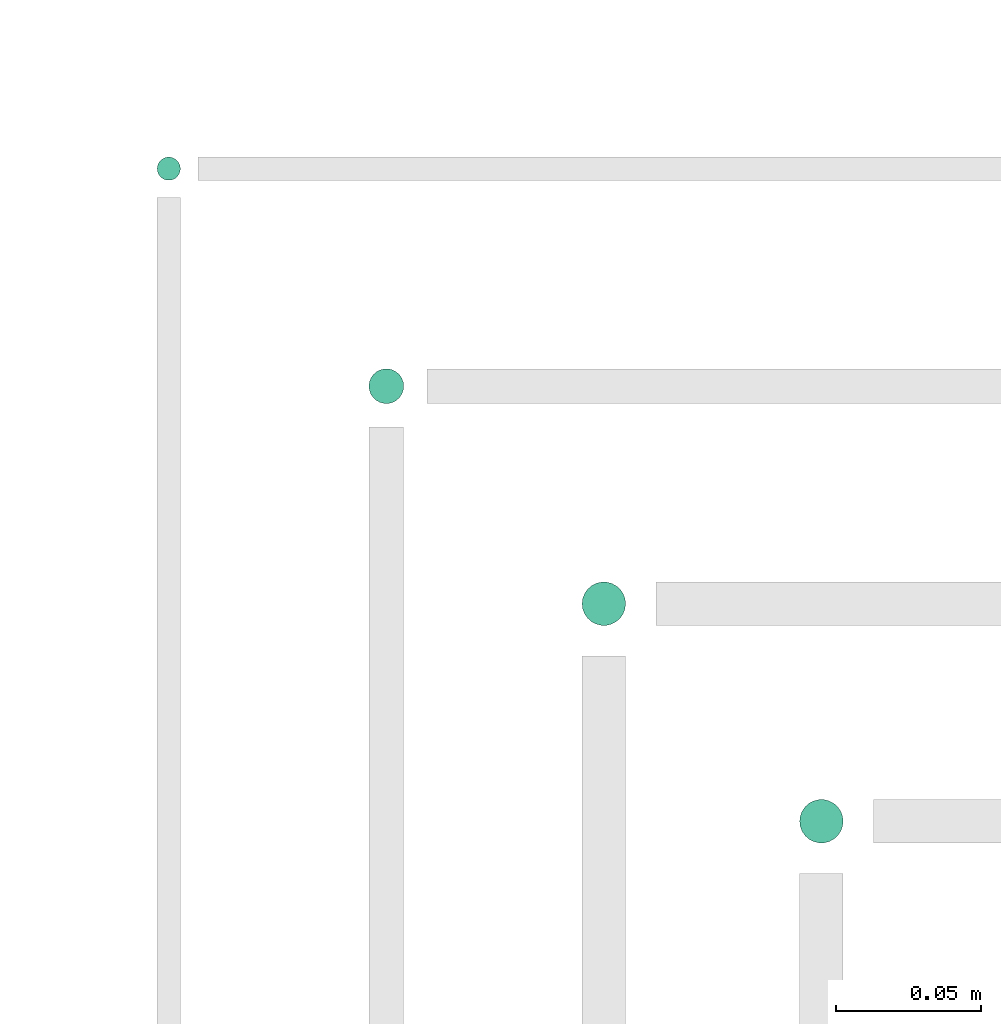
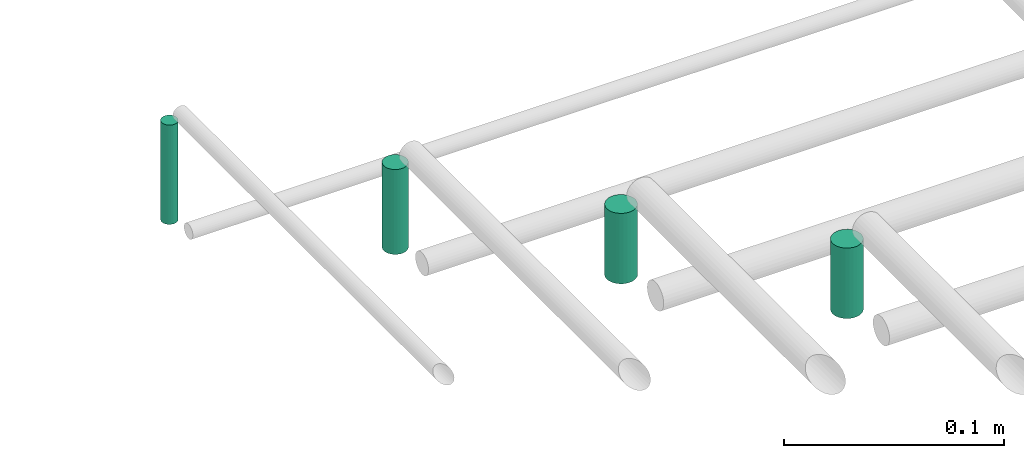
# One storey, part 54 of 65: 4 flow segments.
"""IFC2X3 building model written with IfcOpenShell, lengths in millimetres."""

from ifc_helpers import new_model, entity, si_unit, converted_unit, derived_unit, direction, frame, frame_2d, origin, origin_2d_with_axis, place, context, subcontext, project, spatial, circle, extrude, type_object, element, save


model = new_model("IFC2X3")

# Units and contexts
model_context = context("Model", 3, precision=0.01, world=origin(), true_north=direction((6.12303176911189e-17, 1.0)))
body_context = subcontext(model_context, "Body", "Model", "MODEL_VIEW")
ifc_project = project(units=[si_unit("LENGTHUNIT", "METRE", prefix="MILLI"), si_unit("AREAUNIT", "SQUARE_METRE"), si_unit("VOLUMEUNIT", "CUBIC_METRE"), converted_unit("PLANEANGLEUNIT", "DEGREE", entity("IfcRatioMeasure", 0.0174532925199433), si_unit("PLANEANGLEUNIT", "RADIAN"), dimensions=[0, 0, 0, 0, 0, 0, 0]), si_unit("MASSUNIT", "GRAM", prefix="KILO"), derived_unit("MASSDENSITYUNIT", [(si_unit("MASSUNIT", "GRAM", prefix="KILO"), 1), (si_unit("LENGTHUNIT", "METRE"), -3)]), derived_unit("MOMENTOFINERTIAUNIT", [(si_unit("LENGTHUNIT", "METRE"), 4)]), si_unit("TIMEUNIT", "SECOND"), si_unit("FREQUENCYUNIT", "HERTZ"), si_unit("THERMODYNAMICTEMPERATUREUNIT", "DEGREE_CELSIUS"), derived_unit("THERMALTRANSMITTANCEUNIT", [(si_unit("MASSUNIT", "GRAM", prefix="KILO"), 1), (si_unit("THERMODYNAMICTEMPERATUREUNIT", "KELVIN"), -1), (si_unit("TIMEUNIT", "SECOND"), -3)]), derived_unit("VOLUMETRICFLOWRATEUNIT", [(si_unit("LENGTHUNIT", "METRE"), 3), (si_unit("TIMEUNIT", "SECOND"), -1)]), derived_unit("MASSFLOWRATEUNIT", [(si_unit("MASSUNIT", "GRAM", prefix="KILO"), 1), (si_unit("TIMEUNIT", "SECOND"), -1)]), derived_unit("ROTATIONALFREQUENCYUNIT", [(si_unit("TIMEUNIT", "SECOND"), -1)]), si_unit("ELECTRICCURRENTUNIT", "AMPERE"), si_unit("ELECTRICVOLTAGEUNIT", "VOLT"), si_unit("POWERUNIT", "WATT"), si_unit("FORCEUNIT", "NEWTON", prefix="KILO"), si_unit("ILLUMINANCEUNIT", "LUX"), si_unit("LUMINOUSFLUXUNIT", "LUMEN"), si_unit("LUMINOUSINTENSITYUNIT", "CANDELA"), derived_unit("USERDEFINED", [(si_unit("MASSUNIT", "GRAM", prefix="KILO"), -1), (si_unit("LENGTHUNIT", "METRE"), -2), (si_unit("TIMEUNIT", "SECOND"), 3), (si_unit("LUMINOUSFLUXUNIT", "LUMEN"), 1)]), derived_unit("LINEARVELOCITYUNIT", [(si_unit("LENGTHUNIT", "METRE"), 1), (si_unit("TIMEUNIT", "SECOND"), -1)]), si_unit("PRESSUREUNIT", "PASCAL"), derived_unit("USERDEFINED", [(si_unit("LENGTHUNIT", "METRE"), -2), (si_unit("MASSUNIT", "GRAM", prefix="KILO"), 1), (si_unit("TIMEUNIT", "SECOND"), -2)]), derived_unit("LINEARFORCEUNIT", [(si_unit("MASSUNIT", "GRAM", prefix="KILO"), 1), (si_unit("LENGTHUNIT", "METRE"), 1), (si_unit("TIMEUNIT", "SECOND"), -2), (si_unit("LENGTHUNIT", "METRE"), -1)]), derived_unit("PLANARFORCEUNIT", [(si_unit("MASSUNIT", "GRAM", prefix="KILO"), 1), (si_unit("LENGTHUNIT", "METRE"), 1), (si_unit("TIMEUNIT", "SECOND"), -2), (si_unit("LENGTHUNIT", "METRE"), -2)])], contexts=[model_context])

# Site, building, storey
site_placement = place(None, frame((0.0, -0.00077364408347762, 0.0)))
site = spatial("IfcSite", under=ifc_project, at=site_placement, CompositionType="ELEMENT")
building_placement = place(site_placement, origin())
building = spatial("IfcBuilding", under=site, at=building_placement, CompositionType="ELEMENT")
storey_placement = place(building_placement, frame((0.0, 0.0, 19800.0)))
storey = spatial("IfcBuildingStorey", under=building, at=storey_placement, CompositionType="ELEMENT", Elevation=19800.0)

# Flow segments
pipe_segment_type = type_object("IfcPipeSegmentType", PredefinedType="NOTDEFINED")
for number, where in (
    (1, (37576.7088804252, 10490.591292662, 3093.0)),
    (2, (37501.7088804252, 10565.591292662, 3093.0)),
):
    element("IfcFlowSegment", number, at=place(storey_placement, frame(where)), inside=storey, type_object=pipe_segment_type, context=body_context, shape_type="SweptSolid", body=[
        extrude(circle(Radius=7.5, at=frame_2d((0.0, -2.16573425859679e-12), x_axis=(1.0, 0.0))), frame((9.09527223591419, 9.09527223591419, 0.0), z_axis=(0.0, 0.0, 1.0), x_axis=(-1.0, 0.0, 0.0)), (0.0, 0.0, 1.0), 39.0000000000128),
    ])
flow_segment_1_placement = place(storey_placement, frame((37428.2088804252, 10642.091292662, 3089.0)))
element("IfcFlowSegment", 3, at=flow_segment_1_placement, inside=storey, type_object=pipe_segment_type, context=body_context, shape_type="SweptSolid", body=[
    extrude(circle(Radius=6.0, at=origin_2d_with_axis()), frame((7.59527223591454, 7.5952722359167, 0.0), z_axis=(0.0, 0.0, 1.0), x_axis=(-1.0, 0.0, 0.0)), (0.0, 0.0, 1.0), 47.0000000000066),
])
flow_segment_2_placement = place(storey_placement, frame((37355.2088804252, 10719.091292662, 3085.0)))
element("IfcFlowSegment", 4, at=flow_segment_2_placement, inside=storey, type_object=pipe_segment_type, context=body_context, shape_type="SweptSolid", body=[
    extrude(circle(Radius=4.0, at=origin_2d_with_axis()), frame((5.59527223591499, 5.59527223591499, 0.0), z_axis=(0.0, 0.0, 1.0), x_axis=(-1.0, 0.0, 0.0)), (0.0, 0.0, 1.0), 55.0000000000178),
])

save(model, "model.ifc")
